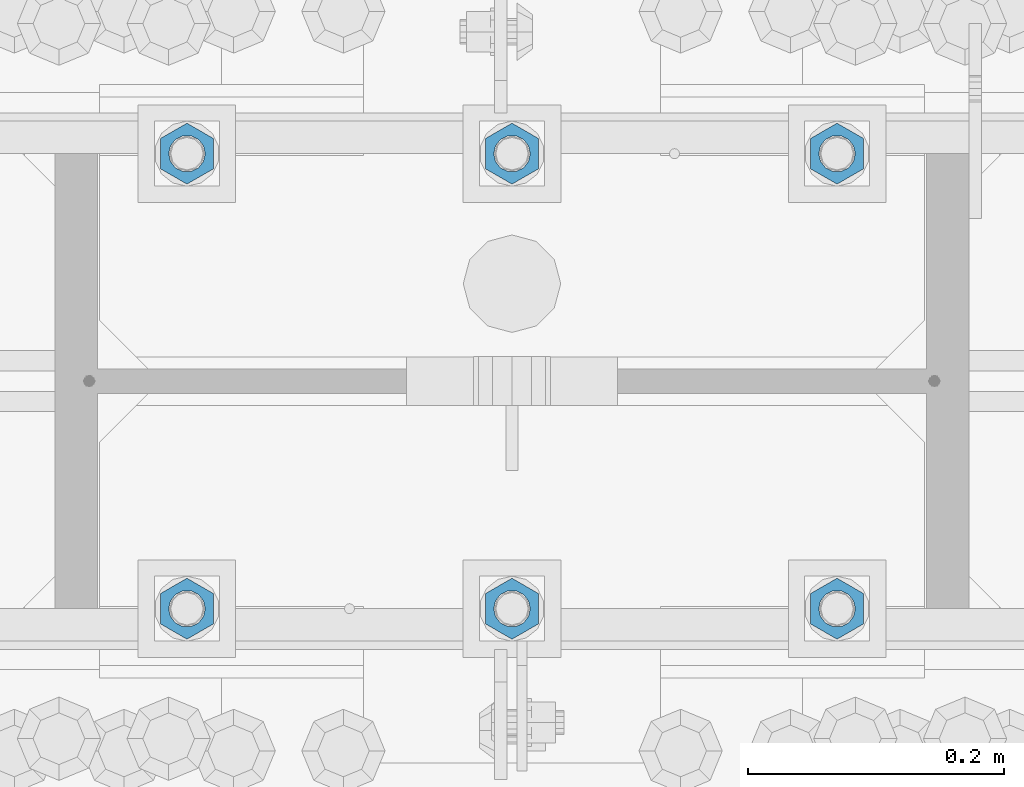
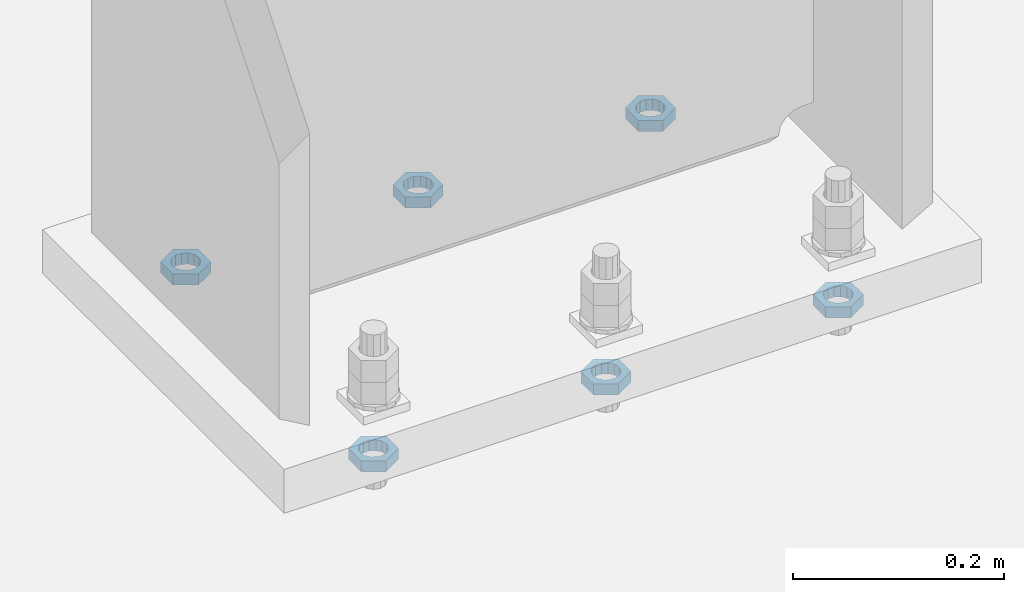
# One storey, part 1405 of 1763: 6 beams, 1 element without a shape of its own.
"""IFC2X3 building model written with IfcOpenShell, lengths in millimetres."""

from ifc_helpers import new_model, si_unit, frame, origin_with_axes, place, context, subcontext, project, spatial, faceted_brep, material, type_object, element, aggregate, save


model = new_model("IFC2X3")

# Units and contexts
model_context = context("Model", 3, precision=1e-05, world=origin_with_axes())
body_context = subcontext(model_context, "Body", "Model", "MODEL_VIEW")
ifc_project = project(units=[si_unit("LENGTHUNIT", "METRE", prefix="MILLI"), si_unit("AREAUNIT", "SQUARE_METRE"), si_unit("VOLUMEUNIT", "CUBIC_METRE"), si_unit("MASSUNIT", "GRAM", prefix="KILO"), si_unit("TIMEUNIT", "SECOND"), si_unit("PLANEANGLEUNIT", "RADIAN"), si_unit("SOLIDANGLEUNIT", "STERADIAN"), si_unit("THERMODYNAMICTEMPERATUREUNIT", "DEGREE_CELSIUS"), si_unit("LUMINOUSINTENSITYUNIT", "LUMEN")], contexts=[model_context])

# Site, building, storey
site_placement = place(None, origin_with_axes())
site = spatial("IfcSite", under=ifc_project, at=site_placement, CompositionType="ELEMENT")
building_placement = place(site_placement, origin_with_axes())
building = spatial("IfcBuilding", under=site, at=building_placement, Name="Undefined", CompositionType="ELEMENT")
storey_placement = place(building_placement, origin_with_axes())
storey = spatial("IfcBuildingStorey", under=building, at=storey_placement, Name="Undefined", CompositionType="ELEMENT", Elevation=0.0)

# Assembly, beams
assembly_placement = place(storey_placement, origin_with_axes())
assembly = element("IfcElementAssembly", 1, at=assembly_placement, inside=storey, Name="TEMPLATE", AssemblyPlace="NOTDEFINED", PredefinedType="RIGID_FRAME")
ifc_material = material(Name="STEEL/A563")
beam_type = type_object("IfcBeamType", Name="1_DIA. HALF_NUT", PredefinedType="NOTDEFINED")
beam_1_placement = place(assembly_placement, frame((-61340.4372736983, 52298.6, -266.699999999996), z_axis=(-1.0, 0.0, 0.0), x_axis=(0.0, 0.0, -1.0)))
beam_1 = element("IfcBeam", 2, at=beam_1_placement, type_object=beam_type, material=ifc_material, Name="NUT", ObjectType="1_DIA. HALF_NUT", context=body_context, shape_type="Brep", body=[
    faceted_brep([(0.0, -23.8099994659424, 0.0), (0.0, -11.9099998474121, -20.6200008392334), (12.7000000000001, -11.9099998474121, -20.6200008392334), (12.7000000000001, -23.8099994659424, 0.0), (0.0, 11.9099998474121, -20.6200008392334), (12.7000000000001, 11.9099998474121, -20.6200008392334), (0.0, 23.8099994659424, 0.0), (12.7000000000001, 23.8099994659424, 0.0), (0.0, 11.9099998474121, 20.6200008392334), (12.7000000000001, 11.9099998474121, 20.6200008392334), (0.0, -11.9099998474121, 20.6200008392334), (12.7000000000001, -11.9099998474121, 20.6200008392334), (0.0, 0.0, 14.289999961853), (0.0, 6.20019861543551, 12.8748450879575), (12.7000000000001, 6.20019861543551, 12.8748450879575), (12.7000000000001, 0.0, 14.289999961853), (0.0, 11.1723718546418, 8.90966924477834), (12.7000000000001, 11.1723718546418, 8.90966924477834), (0.0, 13.9317198278877, 3.17982413774735), (12.7000000000001, 13.9317198278877, 3.17982413774735), (0.0, 13.9317198278877, -3.17982413774735), (12.7000000000001, 13.9317198278877, -3.17982413774735), (0.0, 11.1723718546418, -8.90966924477834), (12.7000000000001, 11.1723718546418, -8.90966924477834), (0.0, 6.20019861543551, -12.8748450879575), (12.7000000000001, 6.20019861543551, -12.8748450879575), (0.0, 0.0, -14.289999961853), (12.7000000000001, 0.0, -14.289999961853), (0.0, -6.20019861543551, -12.8748450879575), (12.7000000000001, -6.20019861543551, -12.8748450879575), (0.0, -11.1723718546418, -8.90966924477834), (12.7000000000001, -11.1723718546418, -8.90966924477834), (0.0, -13.9317198278877, -3.17982413774735), (12.7000000000001, -13.9317198278877, -3.17982413774735), (0.0, -13.9317198278877, 3.17982413774735), (12.7000000000001, -13.9317198278877, 3.17982413774735), (0.0, -11.1723718546418, 8.90966924477834), (12.7000000000001, -11.1723718546418, 8.90966924477834), (0.0, -6.20019861543551, 12.8748450879575), (12.7000000000001, -6.20019861543551, 12.8748450879575)], [[[0, 1, 2, 3]], [[1, 4, 5, 2]], [[4, 6, 7, 5]], [[6, 8, 9, 7]], [[8, 10, 11, 9]], [[10, 0, 3, 11]], [[12, 13, 14, 15]], [[13, 16, 17, 14]], [[16, 18, 19, 17]], [[18, 20, 21, 19]], [[20, 22, 23, 21]], [[22, 24, 25, 23]], [[24, 26, 27, 25]], [[26, 28, 29, 27]], [[28, 30, 31, 29]], [[30, 32, 33, 31]], [[32, 34, 35, 33]], [[34, 36, 37, 35]], [[36, 38, 39, 37]], [[38, 12, 15, 39]], [[5, 7, 9, 11, 3, 2], [17, 19, 21, 23, 25, 27, 29, 31, 33, 35, 37, 39, 15, 14]], [[10, 8, 6, 4, 1, 0], [38, 36, 34, 32, 30, 28, 26, 24, 22, 20, 18, 16, 13, 12]]]),
])
beam_2_placement = place(assembly_placement, frame((-61594.4372736983, 52298.6, -266.699999999996), z_axis=(-1.0, 0.0, 0.0), x_axis=(0.0, 0.0, -1.0)))
beam_2 = element("IfcBeam", 3, at=beam_2_placement, type_object=beam_type, material=ifc_material, Name="NUT", ObjectType="1_DIA. HALF_NUT", context=body_context, shape_type="Brep", body=[
    faceted_brep([(0.0, -23.8099994659424, 0.0), (0.0, -11.9099998474121, -20.6200008392334), (12.7000000000001, -11.9099998474121, -20.6200008392334), (12.7000000000001, -23.8099994659424, 0.0), (0.0, 11.9099998474121, -20.6200008392334), (12.7000000000001, 11.9099998474121, -20.6200008392334), (0.0, 23.8099994659424, 0.0), (12.7000000000001, 23.8099994659424, 0.0), (0.0, 11.9099998474121, 20.6200008392334), (12.7000000000001, 11.9099998474121, 20.6200008392334), (0.0, -11.9099998474121, 20.6200008392334), (12.7000000000001, -11.9099998474121, 20.6200008392334), (0.0, 0.0, 14.289999961853), (0.0, 6.20019861543551, 12.8748450879575), (12.7000000000001, 6.20019861543551, 12.8748450879575), (12.7000000000001, 0.0, 14.289999961853), (0.0, 11.1723718546418, 8.90966924477834), (12.7000000000001, 11.1723718546418, 8.90966924477834), (0.0, 13.9317198278877, 3.17982413774735), (12.7000000000001, 13.9317198278877, 3.17982413774735), (0.0, 13.9317198278877, -3.17982413774735), (12.7000000000001, 13.9317198278877, -3.17982413774735), (0.0, 11.1723718546418, -8.90966924477834), (12.7000000000001, 11.1723718546418, -8.90966924477834), (0.0, 6.20019861543551, -12.8748450879575), (12.7000000000001, 6.20019861543551, -12.8748450879575), (0.0, 0.0, -14.289999961853), (12.7000000000001, 0.0, -14.289999961853), (0.0, -6.20019861543551, -12.8748450879575), (12.7000000000001, -6.20019861543551, -12.8748450879575), (0.0, -11.1723718546418, -8.90966924477834), (12.7000000000001, -11.1723718546418, -8.90966924477834), (0.0, -13.9317198278877, -3.17982413774735), (12.7000000000001, -13.9317198278877, -3.17982413774735), (0.0, -13.9317198278877, 3.17982413774735), (12.7000000000001, -13.9317198278877, 3.17982413774735), (0.0, -11.1723718546418, 8.90966924477834), (12.7000000000001, -11.1723718546418, 8.90966924477834), (0.0, -6.20019861543551, 12.8748450879575), (12.7000000000001, -6.20019861543551, 12.8748450879575)], [[[0, 1, 2, 3]], [[1, 4, 5, 2]], [[4, 6, 7, 5]], [[6, 8, 9, 7]], [[8, 10, 11, 9]], [[10, 0, 3, 11]], [[12, 13, 14, 15]], [[13, 16, 17, 14]], [[16, 18, 19, 17]], [[18, 20, 21, 19]], [[20, 22, 23, 21]], [[22, 24, 25, 23]], [[24, 26, 27, 25]], [[26, 28, 29, 27]], [[28, 30, 31, 29]], [[30, 32, 33, 31]], [[32, 34, 35, 33]], [[34, 36, 37, 35]], [[36, 38, 39, 37]], [[38, 12, 15, 39]], [[5, 7, 9, 11, 3, 2], [17, 19, 21, 23, 25, 27, 29, 31, 33, 35, 37, 39, 15, 14]], [[10, 8, 6, 4, 1, 0], [38, 36, 34, 32, 30, 28, 26, 24, 22, 20, 18, 16, 13, 12]]]),
])
beam_3_placement = place(assembly_placement, frame((-61848.4372736983, 52298.6, -266.699999999996), z_axis=(-1.0, 0.0, 0.0), x_axis=(0.0, 0.0, -1.0)))
beam_3 = element("IfcBeam", 4, at=beam_3_placement, type_object=beam_type, material=ifc_material, Name="NUT", ObjectType="1_DIA. HALF_NUT", context=body_context, shape_type="Brep", body=[
    faceted_brep([(0.0, -23.8099994659424, 0.0), (0.0, -11.9099998474121, -20.6200008392334), (12.7000000000001, -11.9099998474121, -20.6200008392334), (12.7000000000001, -23.8099994659424, 0.0), (0.0, 11.9099998474121, -20.6200008392334), (12.7000000000001, 11.9099998474121, -20.6200008392334), (0.0, 23.8099994659424, 0.0), (12.7000000000001, 23.8099994659424, 0.0), (0.0, 11.9099998474121, 20.6200008392334), (12.7000000000001, 11.9099998474121, 20.6200008392334), (0.0, -11.9099998474121, 20.6200008392334), (12.7000000000001, -11.9099998474121, 20.6200008392334), (0.0, 0.0, 14.289999961853), (0.0, 6.20019861543551, 12.8748450879575), (12.7000000000001, 6.20019861543551, 12.8748450879575), (12.7000000000001, 0.0, 14.289999961853), (0.0, 11.1723718546418, 8.90966924477834), (12.7000000000001, 11.1723718546418, 8.90966924477834), (0.0, 13.9317198278877, 3.17982413774735), (12.7000000000001, 13.9317198278877, 3.17982413774735), (0.0, 13.9317198278877, -3.17982413774735), (12.7000000000001, 13.9317198278877, -3.17982413774735), (0.0, 11.1723718546418, -8.90966924477834), (12.7000000000001, 11.1723718546418, -8.90966924477834), (0.0, 6.20019861543551, -12.8748450879575), (12.7000000000001, 6.20019861543551, -12.8748450879575), (0.0, 0.0, -14.289999961853), (12.7000000000001, 0.0, -14.289999961853), (0.0, -6.20019861543551, -12.8748450879575), (12.7000000000001, -6.20019861543551, -12.8748450879575), (0.0, -11.1723718546418, -8.90966924477834), (12.7000000000001, -11.1723718546418, -8.90966924477834), (0.0, -13.9317198278877, -3.17982413774735), (12.7000000000001, -13.9317198278877, -3.17982413774735), (0.0, -13.9317198278877, 3.17982413774735), (12.7000000000001, -13.9317198278877, 3.17982413774735), (0.0, -11.1723718546418, 8.90966924477834), (12.7000000000001, -11.1723718546418, 8.90966924477834), (0.0, -6.20019861543551, 12.8748450879575), (12.7000000000001, -6.20019861543551, 12.8748450879575)], [[[0, 1, 2, 3]], [[1, 4, 5, 2]], [[4, 6, 7, 5]], [[6, 8, 9, 7]], [[8, 10, 11, 9]], [[10, 0, 3, 11]], [[12, 13, 14, 15]], [[13, 16, 17, 14]], [[16, 18, 19, 17]], [[18, 20, 21, 19]], [[20, 22, 23, 21]], [[22, 24, 25, 23]], [[24, 26, 27, 25]], [[26, 28, 29, 27]], [[28, 30, 31, 29]], [[30, 32, 33, 31]], [[32, 34, 35, 33]], [[34, 36, 37, 35]], [[36, 38, 39, 37]], [[38, 12, 15, 39]], [[5, 7, 9, 11, 3, 2], [17, 19, 21, 23, 25, 27, 29, 31, 33, 35, 37, 39, 15, 14]], [[10, 8, 6, 4, 1, 0], [38, 36, 34, 32, 30, 28, 26, 24, 22, 20, 18, 16, 13, 12]]]),
])
beam_4_placement = place(assembly_placement, frame((-61848.4372736983, 51943.0, -266.699999999996), z_axis=(1.0, 0.0, 0.0), x_axis=(0.0, 0.0, -1.0)))
beam_4 = element("IfcBeam", 5, at=beam_4_placement, type_object=beam_type, material=ifc_material, Name="NUT", ObjectType="1_DIA. HALF_NUT", context=body_context, shape_type="Brep", body=[
    faceted_brep([(0.0, -23.8099994659424, 0.0), (0.0, -11.9099998474121, -20.6200008392334), (12.7000000000001, -11.9099998474121, -20.6200008392334), (12.7000000000001, -23.8099994659424, 0.0), (0.0, 11.9099998474121, -20.6200008392334), (12.7000000000001, 11.9099998474121, -20.6200008392334), (0.0, 23.8099994659424, 0.0), (12.7000000000001, 23.8099994659424, 0.0), (0.0, 11.9099998474121, 20.6200008392334), (12.7000000000001, 11.9099998474121, 20.6200008392334), (0.0, -11.9099998474121, 20.6200008392334), (12.7000000000001, -11.9099998474121, 20.6200008392334), (0.0, 0.0, 14.289999961853), (0.0, 6.20019861543551, 12.8748450879575), (12.7000000000001, 6.20019861543551, 12.8748450879575), (12.7000000000001, 0.0, 14.289999961853), (0.0, 11.1723718546418, 8.90966924477834), (12.7000000000001, 11.1723718546418, 8.90966924477834), (0.0, 13.9317198278877, 3.17982413774735), (12.7000000000001, 13.9317198278877, 3.17982413774735), (0.0, 13.9317198278877, -3.17982413774735), (12.7000000000001, 13.9317198278877, -3.17982413774735), (0.0, 11.1723718546418, -8.90966924477834), (12.7000000000001, 11.1723718546418, -8.90966924477834), (0.0, 6.20019861543551, -12.8748450879575), (12.7000000000001, 6.20019861543551, -12.8748450879575), (0.0, 0.0, -14.289999961853), (12.7000000000001, 0.0, -14.289999961853), (0.0, -6.20019861543551, -12.8748450879575), (12.7000000000001, -6.20019861543551, -12.8748450879575), (0.0, -11.1723718546418, -8.90966924477834), (12.7000000000001, -11.1723718546418, -8.90966924477834), (0.0, -13.9317198278877, -3.17982413774735), (12.7000000000001, -13.9317198278877, -3.17982413774735), (0.0, -13.9317198278877, 3.17982413774735), (12.7000000000001, -13.9317198278877, 3.17982413774735), (0.0, -11.1723718546418, 8.90966924477834), (12.7000000000001, -11.1723718546418, 8.90966924477834), (0.0, -6.20019861543551, 12.8748450879575), (12.7000000000001, -6.20019861543551, 12.8748450879575)], [[[0, 1, 2, 3]], [[1, 4, 5, 2]], [[4, 6, 7, 5]], [[6, 8, 9, 7]], [[8, 10, 11, 9]], [[10, 0, 3, 11]], [[12, 13, 14, 15]], [[13, 16, 17, 14]], [[16, 18, 19, 17]], [[18, 20, 21, 19]], [[20, 22, 23, 21]], [[22, 24, 25, 23]], [[24, 26, 27, 25]], [[26, 28, 29, 27]], [[28, 30, 31, 29]], [[30, 32, 33, 31]], [[32, 34, 35, 33]], [[34, 36, 37, 35]], [[36, 38, 39, 37]], [[38, 12, 15, 39]], [[5, 7, 9, 11, 3, 2], [17, 19, 21, 23, 25, 27, 29, 31, 33, 35, 37, 39, 15, 14]], [[10, 8, 6, 4, 1, 0], [38, 36, 34, 32, 30, 28, 26, 24, 22, 20, 18, 16, 13, 12]]]),
])
beam_5_placement = place(assembly_placement, frame((-61594.4372736983, 51943.0, -266.699999999996), z_axis=(1.0, 0.0, 0.0), x_axis=(0.0, 0.0, -1.0)))
beam_5 = element("IfcBeam", 6, at=beam_5_placement, type_object=beam_type, material=ifc_material, Name="NUT", ObjectType="1_DIA. HALF_NUT", context=body_context, shape_type="Brep", body=[
    faceted_brep([(0.0, -23.8099994659424, 0.0), (0.0, -11.9099998474121, -20.6200008392334), (12.7000000000001, -11.9099998474121, -20.6200008392334), (12.7000000000001, -23.8099994659424, 0.0), (0.0, 11.9099998474121, -20.6200008392334), (12.7000000000001, 11.9099998474121, -20.6200008392334), (0.0, 23.8099994659424, 0.0), (12.7000000000001, 23.8099994659424, 0.0), (0.0, 11.9099998474121, 20.6200008392334), (12.7000000000001, 11.9099998474121, 20.6200008392334), (0.0, -11.9099998474121, 20.6200008392334), (12.7000000000001, -11.9099998474121, 20.6200008392334), (0.0, 0.0, 14.289999961853), (0.0, 6.20019861543551, 12.8748450879575), (12.7000000000001, 6.20019861543551, 12.8748450879575), (12.7000000000001, 0.0, 14.289999961853), (0.0, 11.1723718546418, 8.90966924477834), (12.7000000000001, 11.1723718546418, 8.90966924477834), (0.0, 13.9317198278877, 3.17982413774735), (12.7000000000001, 13.9317198278877, 3.17982413774735), (0.0, 13.9317198278877, -3.17982413774735), (12.7000000000001, 13.9317198278877, -3.17982413774735), (0.0, 11.1723718546418, -8.90966924477834), (12.7000000000001, 11.1723718546418, -8.90966924477834), (0.0, 6.20019861543551, -12.8748450879575), (12.7000000000001, 6.20019861543551, -12.8748450879575), (0.0, 0.0, -14.289999961853), (12.7000000000001, 0.0, -14.289999961853), (0.0, -6.20019861543551, -12.8748450879575), (12.7000000000001, -6.20019861543551, -12.8748450879575), (0.0, -11.1723718546418, -8.90966924477834), (12.7000000000001, -11.1723718546418, -8.90966924477834), (0.0, -13.9317198278877, -3.17982413774735), (12.7000000000001, -13.9317198278877, -3.17982413774735), (0.0, -13.9317198278877, 3.17982413774735), (12.7000000000001, -13.9317198278877, 3.17982413774735), (0.0, -11.1723718546418, 8.90966924477834), (12.7000000000001, -11.1723718546418, 8.90966924477834), (0.0, -6.20019861543551, 12.8748450879575), (12.7000000000001, -6.20019861543551, 12.8748450879575)], [[[0, 1, 2, 3]], [[1, 4, 5, 2]], [[4, 6, 7, 5]], [[6, 8, 9, 7]], [[8, 10, 11, 9]], [[10, 0, 3, 11]], [[12, 13, 14, 15]], [[13, 16, 17, 14]], [[16, 18, 19, 17]], [[18, 20, 21, 19]], [[20, 22, 23, 21]], [[22, 24, 25, 23]], [[24, 26, 27, 25]], [[26, 28, 29, 27]], [[28, 30, 31, 29]], [[30, 32, 33, 31]], [[32, 34, 35, 33]], [[34, 36, 37, 35]], [[36, 38, 39, 37]], [[38, 12, 15, 39]], [[5, 7, 9, 11, 3, 2], [17, 19, 21, 23, 25, 27, 29, 31, 33, 35, 37, 39, 15, 14]], [[10, 8, 6, 4, 1, 0], [38, 36, 34, 32, 30, 28, 26, 24, 22, 20, 18, 16, 13, 12]]]),
])
beam_6_placement = place(assembly_placement, frame((-61340.4372736983, 51943.0, -266.699999999996), z_axis=(1.0, 0.0, 0.0), x_axis=(0.0, 0.0, -1.0)))
beam_6 = element("IfcBeam", 7, at=beam_6_placement, type_object=beam_type, material=ifc_material, Name="NUT", ObjectType="1_DIA. HALF_NUT", context=body_context, shape_type="Brep", body=[
    faceted_brep([(0.0, -23.8099994659424, 0.0), (0.0, -11.9099998474121, -20.6200008392334), (12.7000000000001, -11.9099998474121, -20.6200008392334), (12.7000000000001, -23.8099994659424, 0.0), (0.0, 11.9099998474121, -20.6200008392334), (12.7000000000001, 11.9099998474121, -20.6200008392334), (0.0, 23.8099994659424, 0.0), (12.7000000000001, 23.8099994659424, 0.0), (0.0, 11.9099998474121, 20.6200008392334), (12.7000000000001, 11.9099998474121, 20.6200008392334), (0.0, -11.9099998474121, 20.6200008392334), (12.7000000000001, -11.9099998474121, 20.6200008392334), (0.0, 0.0, 14.289999961853), (0.0, 6.20019861543551, 12.8748450879575), (12.7000000000001, 6.20019861543551, 12.8748450879575), (12.7000000000001, 0.0, 14.289999961853), (0.0, 11.1723718546418, 8.90966924477834), (12.7000000000001, 11.1723718546418, 8.90966924477834), (0.0, 13.9317198278877, 3.17982413774735), (12.7000000000001, 13.9317198278877, 3.17982413774735), (0.0, 13.9317198278877, -3.17982413774735), (12.7000000000001, 13.9317198278877, -3.17982413774735), (0.0, 11.1723718546418, -8.90966924477834), (12.7000000000001, 11.1723718546418, -8.90966924477834), (0.0, 6.20019861543551, -12.8748450879575), (12.7000000000001, 6.20019861543551, -12.8748450879575), (0.0, 0.0, -14.289999961853), (12.7000000000001, 0.0, -14.289999961853), (0.0, -6.20019861543551, -12.8748450879575), (12.7000000000001, -6.20019861543551, -12.8748450879575), (0.0, -11.1723718546418, -8.90966924477834), (12.7000000000001, -11.1723718546418, -8.90966924477834), (0.0, -13.9317198278877, -3.17982413774735), (12.7000000000001, -13.9317198278877, -3.17982413774735), (0.0, -13.9317198278877, 3.17982413774735), (12.7000000000001, -13.9317198278877, 3.17982413774735), (0.0, -11.1723718546418, 8.90966924477834), (12.7000000000001, -11.1723718546418, 8.90966924477834), (0.0, -6.20019861543551, 12.8748450879575), (12.7000000000001, -6.20019861543551, 12.8748450879575)], [[[0, 1, 2, 3]], [[1, 4, 5, 2]], [[4, 6, 7, 5]], [[6, 8, 9, 7]], [[8, 10, 11, 9]], [[10, 0, 3, 11]], [[12, 13, 14, 15]], [[13, 16, 17, 14]], [[16, 18, 19, 17]], [[18, 20, 21, 19]], [[20, 22, 23, 21]], [[22, 24, 25, 23]], [[24, 26, 27, 25]], [[26, 28, 29, 27]], [[28, 30, 31, 29]], [[30, 32, 33, 31]], [[32, 34, 35, 33]], [[34, 36, 37, 35]], [[36, 38, 39, 37]], [[38, 12, 15, 39]], [[5, 7, 9, 11, 3, 2], [17, 19, 21, 23, 25, 27, 29, 31, 33, 35, 37, 39, 15, 14]], [[10, 8, 6, 4, 1, 0], [38, 36, 34, 32, 30, 28, 26, 24, 22, 20, 18, 16, 13, 12]]]),
])
aggregate(assembly, [beam_1, beam_2, beam_3, beam_4, beam_5, beam_6])

save(model, "model.ifc")
